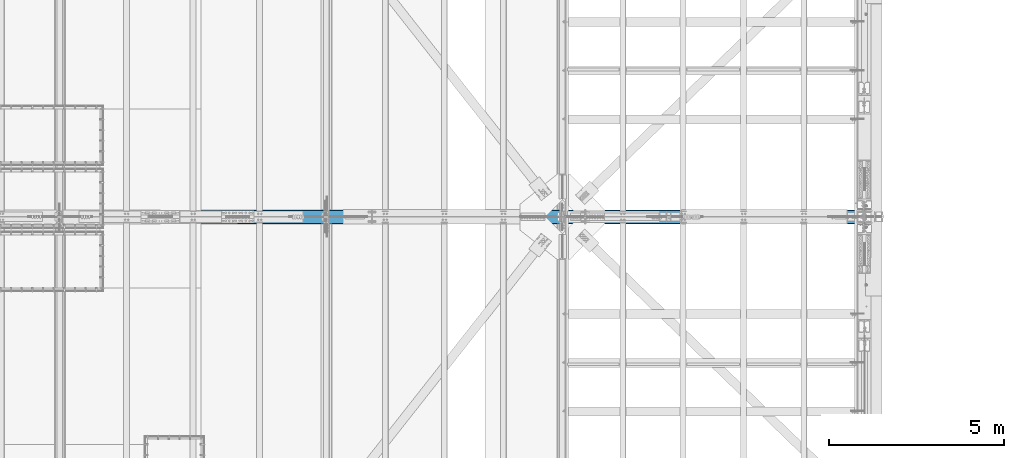
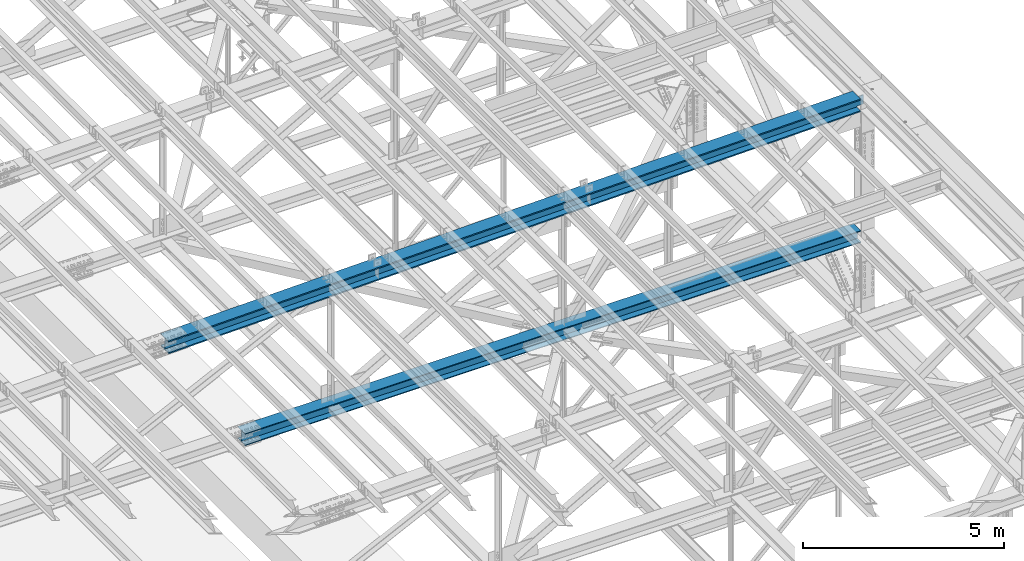
# One storey, part 1861 of 3843: 2 beams, 2 elements without a shape of their own.
"""IFC2X3 building model written with IfcOpenShell, lengths in millimetres."""

from ifc_helpers import new_model, si_unit, frame, origin_with_axes, place, context, subcontext, project, spatial, faceted_brep, material, type_object, element, aggregate, save


model = new_model("IFC2X3")

# Units and contexts
model_context = context("Model", 3, precision=1e-05, world=origin_with_axes())
body_context = subcontext(model_context, "Body", "Model", "MODEL_VIEW")
ifc_project = project(units=[si_unit("LENGTHUNIT", "METRE", prefix="MILLI"), si_unit("AREAUNIT", "SQUARE_METRE"), si_unit("VOLUMEUNIT", "CUBIC_METRE"), si_unit("MASSUNIT", "GRAM", prefix="KILO"), si_unit("TIMEUNIT", "SECOND"), si_unit("PLANEANGLEUNIT", "RADIAN"), si_unit("SOLIDANGLEUNIT", "STERADIAN"), si_unit("THERMODYNAMICTEMPERATUREUNIT", "DEGREE_CELSIUS"), si_unit("LUMINOUSINTENSITYUNIT", "LUMEN")], contexts=[model_context])

# Site, building, storey
site_placement = place(None, origin_with_axes())
site = spatial("IfcSite", under=ifc_project, at=site_placement, CompositionType="ELEMENT")
building_placement = place(site_placement, origin_with_axes())
building = spatial("IfcBuilding", under=site, at=building_placement, Name="Undefined", CompositionType="ELEMENT")
storey_placement = place(building_placement, origin_with_axes())
storey = spatial("IfcBuildingStorey", under=building, at=storey_placement, Name="Undefined", CompositionType="ELEMENT", Elevation=0.0)

# Assembly, beam
assembly_1_placement = place(storey_placement, origin_with_axes())
assembly_1 = element("IfcElementAssembly", 1, at=assembly_1_placement, inside=storey, Name="BEAM", AssemblyPlace="NOTDEFINED", PredefinedType="RIGID_FRAME")
ifc_material = material(Name="STEEL/A992")
beam_type_1 = type_object("IfcBeamType", Name="W14X193", PredefinedType="NOTDEFINED")
beam_1_placement = place(assembly_1_placement, frame((65510.9044385389, 58915.3, 45934.1237435412), z_axis=(-0.0199480780058802, 0.0, 0.999801017294877), x_axis=(0.999801017294877, 0.0, 0.0199480780058834)))
beam_1 = element("IfcBeam", 2, at=beam_1_placement, type_object=beam_type_1, material=ifc_material, Name="BEAM", ObjectType="W14X193", context=body_context, shape_type="Brep", body=[
    faceted_brep([(19920.5114009357, -11.1125000000029, -159.949242872433), (19920.5114009357, -200.025000000001, -159.949242872433), (19920.4414638508, -200.025000000001, -196.461675867919), (19920.4414638508, 200.025000000001, -196.461675867919), (19920.5114009357, 200.025000000001, -159.949242872433), (19920.5114009357, 11.1125000000029, -159.949242872433), (19920.5266857542, 11.1125000000029, -151.969414858671), (19920.5266857542, -11.1125000000029, -151.969414858671), (19921.5027230384, 11.1125000000029, -147.11119595827), (19921.5027230384, -11.1125000000029, -147.11119595827), (19924.2636237923, 11.1125000000029, -142.996300249775), (19924.2636237923, -11.1125000000029, -142.996300249775), (19928.3890659036, 11.1125000000029, -140.25118330316), (19928.3890659036, -11.1125000000029, -140.25118330316), (19933.2509882082, 11.1125000000029, -139.293764288996), (19933.2509882082, -11.1125000000029, -139.293764288996), (20111.3306712136, -11.1125000000029, -139.634863821506), (20111.3306712136, 11.1125000000029, -139.634863821506), (16116.5916279594, 200.025000000001, 203.035264288184), (16116.5916279594, -200.025000000001, 203.035264288184), (18131.211910055, -200.025000000001, 200.329052298759), (18131.211910055, 200.025000000001, 200.329052298759), (14101.9704556068, 200.025000000001, 204.968273136503), (14101.9704556068, -200.025000000001, 204.968273136503), (12087.3486897496, 200.025000000001, 206.128078558737), (12087.3486897496, -200.025000000001, 206.128078558737), (10072.72662714, 200.025000000001, 206.514680384433), (10072.72662714, -200.025000000001, 206.514680384433), (8058.10456453034, 200.025000000001, 206.128078555856), (8058.10456453034, -200.025000000001, 206.128078555856), (6043.48279867311, 200.025000000001, 204.968273130726), (6043.48279867311, -200.025000000001, 204.968273130726), (4028.86162632053, 200.025000000001, 203.035264279511), (4028.86162632053, -200.025000000001, 203.035264279511), (2014.24134422491, 200.025000000001, 200.329052287198), (2014.24134422491, -200.025000000001, 200.329052287198), (5.97224307589931, 200.024999999994, 196.860604494032), (5.97224307589931, -200.024999999994, 196.860604494032), (18131.155856689, 11.1125000000029, 163.816595324934), (18131.155856689, 200.025000000001, 163.816595324934), (19927.4756215503, 200.025000000001, 160.71420169132), (19927.4756215503, 11.1125000000029, 160.71420169132), (16116.5495879277, 11.1125000000029, 166.522788490438), (16116.5495879277, 200.025000000001, 166.522788490438), (14101.9424289156, 11.1125000000029, 168.4557838931), (14101.9424289156, 200.025000000001, 168.4557838931), (12087.3346764029, 11.1125000000029, 169.615581247934), (12087.3346764029, 200.025000000001, 169.615581247934), (10072.72662714, 11.1125000000029, 170.002180384494), (10072.72662714, 200.025000000001, 170.002180384494), (8058.11857787705, 11.1125000000029, 169.615581245045), (8058.11857787705, 200.025000000001, 169.615581245045), (6043.51082536438, 11.1125000000029, 168.45578388733), (6043.51082536438, 200.025000000001, 168.45578388733), (4028.90366635231, 11.1125000000029, 166.522788481765), (4028.90366635231, 200.025000000001, 166.522788481765), (2014.29739759097, 11.1125000000029, 163.816595313379), (2014.29739759097, 200.025000000001, 163.816595313379), (6.04230920456757, 11.1125000000029, 160.348171721198), (6.04230920456757, 200.024999999994, 160.348171721198), (16116.1803667795, 200.025000000001, -154.151998950634), (16116.1803667795, 11.1125000000029, -154.151998950634), (18130.6635619093, 11.1125000000029, -156.858026793001), (18130.6635619093, 200.025000000001, -156.858026793001), (14101.6962814533, 200.025000000001, -152.219121635942), (14101.6962814533, 11.1125000000029, -152.219121635942), (12087.2116026629, 200.025000000001, -151.059395133896), (12087.2116026629, 11.1125000000029, -151.059395133896), (10072.7266271402, 200.025000000001, -150.67281961492), (10072.7266271402, 11.1125000000029, -150.67281961492), (8058.24165161759, 200.025000000001, -151.059395136777), (8058.24165161759, 11.1125000000029, -151.059395136777), (6043.75697282712, 200.025000000001, -152.219121641712), (6043.75697282712, 11.1125000000029, -152.219121641712), (4029.27288750096, 200.025000000001, -154.1519989593), (4029.27288750096, 11.1125000000029, -154.1519989593), (2014.78969237115, 200.025000000001, -156.858026804548), (2014.78969237115, 11.1125000000029, -156.858026804548), (6.657672595451, 200.024999999994, -160.326237848931), (6.657672595451, 11.1125000000029, -160.326237848931), (16116.1383267478, -200.025000000001, -190.664474748381), (16116.1383267478, 200.025000000001, -190.664474748381), (18130.6075085433, 200.025000000001, -193.370483766819), (18130.6075085433, -200.025000000001, -193.370483766819), (14101.6682547621, -200.025000000001, -188.731610879346), (14101.6682547621, 200.025000000001, -188.731610879346), (12087.1975893162, -200.025000000001, -187.571892444692), (12087.1975893162, 200.025000000001, -187.571892444692), (10072.7266271403, -200.025000000001, -187.185319614859), (10072.7266271403, 200.025000000001, -187.185319614859), (8058.25566496428, -200.025000000001, -187.57189244758), (8058.25566496428, 200.025000000001, -187.57189244758), (6043.78499951842, -200.025000000001, -188.731610885123), (6043.78499951842, 200.025000000001, -188.731610885123), (4029.31492753273, -200.025000000001, -190.664474757039), (4029.31492753273, 200.025000000001, -190.664474757039), (2014.84574573721, -200.025000000001, -193.370483778381), (2014.84574573721, 200.025000000001, -193.370483778381), (6.72773872410471, -200.024999999994, -196.838670621779), (6.72773872410471, 200.024999999994, -196.838670621779), (16116.1803667795, -11.1125000000029, -154.151998950634), (16116.1803667795, -200.025000000001, -154.151998950634), (18130.6635619093, -200.025000000001, -156.858026793001), (18130.6635619093, -11.1125000000029, -156.858026793001), (14101.6962814533, -11.1125000000029, -152.219121635942), (14101.6962814533, -200.025000000001, -152.219121635942), (12087.2116026629, -11.1125000000029, -151.059395133896), (12087.2116026629, -200.025000000001, -151.059395133896), (10072.7266271402, -11.1125000000029, -150.67281961492), (10072.7266271402, -200.025000000001, -150.67281961492), (8058.24165161759, -11.1125000000029, -151.059395136777), (8058.24165161759, -200.025000000001, -151.059395136777), (6043.75697282712, -11.1125000000029, -152.219121641712), (6043.75697282712, -200.025000000001, -152.219121641712), (4029.27288750096, -11.1125000000029, -154.1519989593), (4029.27288750096, -200.025000000001, -154.1519989593), (2014.78969237115, -11.1125000000029, -156.858026804548), (2014.78969237115, -200.025000000001, -156.858026804548), (6.657672595451, -11.1125000000029, -160.326237848931), (6.657672595451, -200.024999999994, -160.326237848931), (6.04230920456757, -11.1125000000029, 160.348171721198), (6.04230920456757, -200.024999999994, 160.348171721198), (2014.29739759097, -11.1125000000029, 163.816595313379), (2014.29739759097, -200.025000000001, 163.816595313379), (4028.90366635231, -11.1125000000029, 166.522788481765), (4028.90366635231, -200.025000000001, 166.522788481765), (6043.51082536438, -11.1125000000029, 168.45578388733), (6043.51082536438, -200.025000000001, 168.45578388733), (8058.11857787705, -11.1125000000029, 169.615581245045), (8058.11857787705, -200.025000000001, 169.615581245045), (10072.72662714, -11.1125000000029, 170.002180384494), (10072.72662714, -200.025000000001, 170.002180384494), (12087.3346764029, -11.1125000000029, 169.615581247934), (12087.3346764029, -200.025000000001, 169.615581247934), (14101.9424289156, -11.1125000000029, 168.4557838931), (14101.9424289156, -200.025000000001, 168.4557838931), (16116.5495879277, -11.1125000000029, 166.522788490438), (16116.5495879277, -200.025000000001, 166.522788490438), (18131.155856689, -11.1125000000029, 163.816595324934), (18131.155856689, -200.025000000001, 163.816595324934), (19927.4756215503, -11.1125000000029, 160.71420169132), (19927.4756215503, -200.025000000001, 160.71420169132), (19927.5455586348, -200.025000000001, 197.226634686813), (19927.5455586348, 200.025000000001, 197.226634686813), (19927.4604966495, -11.1125000000029, 152.817862655196), (19927.4604966495, 11.1125000000029, 152.817862655196), (19928.4179156636, -11.1125000000029, 147.955940350577), (19928.4179156636, 11.1125000000029, 147.955940350577), (19931.1630326103, -11.1125000000029, 143.830498239236), (19931.1630326103, 11.1125000000029, 143.830498239236), (19935.2779283188, -11.1125000000029, 141.06959748541), (19935.2779283188, 11.1125000000029, 141.06959748541), (19940.1361472193, -11.1125000000029, 140.093560201218), (19940.1361472193, 11.1125000000029, 140.093560201218), (20116.9050706485, -11.1125000000029, 139.754971339607), (20116.9050706485, 11.1125000000029, 139.754971339607)], [[[0, 1, 2, 3, 4, 5, 6, 7]], [[7, 6, 8, 9]], [[9, 8, 10, 11]], [[11, 10, 12, 13]], [[13, 12, 14, 15]], [[16, 15, 14, 17]], [[18, 19, 20, 21]], [[22, 23, 19, 18]], [[24, 25, 23, 22]], [[26, 27, 25, 24]], [[28, 29, 27, 26]], [[30, 31, 29, 28]], [[32, 33, 31, 30]], [[34, 35, 33, 32]], [[35, 34, 36, 37]], [[38, 39, 40, 41]], [[42, 43, 39, 38]], [[44, 45, 43, 42]], [[46, 47, 45, 44]], [[48, 49, 47, 46]], [[50, 51, 49, 48]], [[52, 53, 51, 50]], [[54, 55, 53, 52]], [[56, 57, 55, 54]], [[57, 56, 58, 59]], [[60, 61, 62, 63]], [[64, 65, 61, 60]], [[66, 67, 65, 64]], [[68, 69, 67, 66]], [[70, 71, 69, 68]], [[72, 73, 71, 70]], [[74, 75, 73, 72]], [[76, 77, 75, 74]], [[77, 76, 78, 79]], [[80, 81, 82, 83]], [[84, 85, 81, 80]], [[86, 87, 85, 84]], [[88, 89, 87, 86]], [[90, 91, 89, 88]], [[92, 93, 91, 90]], [[94, 95, 93, 92]], [[96, 97, 95, 94]], [[97, 96, 98, 99]], [[100, 101, 102, 103]], [[104, 105, 101, 100]], [[106, 107, 105, 104]], [[108, 109, 107, 106]], [[110, 111, 109, 108]], [[112, 113, 111, 110]], [[114, 115, 113, 112]], [[116, 117, 115, 114]], [[117, 116, 118, 119]], [[120, 121, 37, 36, 59, 58, 79, 78, 99, 98, 119, 118]], [[122, 123, 121, 120]], [[123, 122, 124, 125]], [[125, 124, 126, 127]], [[127, 126, 128, 129]], [[129, 128, 130, 131]], [[131, 130, 132, 133]], [[133, 132, 134, 135]], [[135, 134, 136, 137]], [[137, 136, 138, 139]], [[139, 138, 140, 141]], [[20, 19, 23, 25, 27, 29, 31, 33, 35, 37, 121, 123, 125, 127, 129, 131, 133, 135, 137, 139, 141, 142]], [[21, 20, 142, 143]], [[39, 43, 45, 47, 49, 51, 53, 55, 57, 59, 36, 34, 32, 30, 28, 26, 24, 22, 18, 21, 143, 40]], [[142, 141, 140, 144, 145, 41, 40, 143]], [[146, 147, 145, 144]], [[148, 149, 147, 146]], [[150, 151, 149, 148]], [[152, 153, 151, 150]], [[154, 155, 153, 152]], [[155, 154, 16, 17]], [[12, 10, 8, 6, 5, 62, 61, 65, 67, 69, 71, 73, 75, 77, 79, 58, 56, 54, 52, 50, 48, 46, 44, 42, 38, 41, 145, 147, 149, 151, 153, 155, 17, 14]], [[63, 62, 5, 4]], [[82, 81, 85, 87, 89, 91, 93, 95, 97, 99, 78, 76, 74, 72, 70, 68, 66, 64, 60, 63, 4, 3]], [[83, 82, 3, 2]], [[102, 101, 105, 107, 109, 111, 113, 115, 117, 119, 98, 96, 94, 92, 90, 88, 86, 84, 80, 83, 2, 1]], [[103, 102, 1, 0]], [[154, 152, 150, 148, 146, 144, 140, 138, 136, 134, 132, 130, 128, 126, 124, 122, 120, 118, 116, 114, 112, 110, 108, 106, 104, 100, 103, 0, 7, 9, 11, 13, 15, 16]]]),
])
aggregate(assembly_1, [beam_1])

assembly_2_placement = place(storey_placement, origin_with_axes())
assembly_2 = element("IfcElementAssembly", 3, at=assembly_2_placement, inside=storey, Name="BEAM", AssemblyPlace="NOTDEFINED", PredefinedType="RIGID_FRAME")
beam_type_2 = type_object("IfcBeamType", Name="W14X120", PredefinedType="NOTDEFINED")
beam_2_placement = place(assembly_2_placement, frame((67716.4000147658, 58915.3, 42348.1053377418), z_axis=(0.00141386700069416, 0.0, 0.999999000489553), x_axis=(0.999999000489553, 0.0, -0.00141386700069231)))
beam_2 = element("IfcBeam", 4, at=beam_2_placement, type_object=beam_type_2, material=ifc_material, Name="BEAM", ObjectType="W14X120", context=body_context, shape_type="Brep", body=[
    faceted_brep([(3586.3175087303, -185.737500000003, 165.240491250122), (3586.3175087303, -7.14375000000291, 165.240491250122), (5379.61430858172, -7.14375000000291, 166.772749488926), (5379.61430858172, -185.737500000003, 166.772749488926), (1793.02133730304, -185.737500000003, 163.095329965741), (1793.02133730304, -7.14375000000291, 163.095329965741), (6.07599532067252, -185.737500000003, 160.347032091391), (6.07599532067252, -7.14375000000291, 160.347032091391), (14346.1248180988, 185.737500000003, 189.052978727159), (14346.1248180988, -185.737500000003, 189.052978727159), (16139.4291280259, -185.737500000003, 186.9078077054), (16139.4291280259, 185.737500000003, 186.9078077054), (12552.8198797447, 185.737500000003, 190.5852439218), (12552.8198797447, -185.737500000003, 190.5852439218), (10759.5145224392, 185.737500000003, 191.504603110516), (10759.5145224392, -185.737500000003, 191.504603110516), (8966.20895565808, 185.737500000003, 191.811056186198), (8966.20895565808, -185.737500000003, 191.811056186198), (7172.90338887693, 185.737500000003, 191.504603112524), (7172.90338887693, -185.737500000003, 191.504603112524), (5379.59803157147, 185.737500000003, 190.585243925801), (5379.59803157147, -185.737500000003, 190.585243925801), (3586.29309321741, 185.737500000003, 189.052978733162), (3586.29309321741, -185.737500000003, 189.052978733162), (1792.98878329033, 185.737500000003, 186.907807713411), (1792.98878329033, -185.737500000003, 186.907807713411), (6.03530269260227, 185.737500000003, 184.159497322114), (6.03530269260227, -185.737500000003, 184.159497322114), (14346.1004025862, 7.14375000000291, 165.240491244112), (14346.1004025862, 185.737500000003, 165.240491244112), (16139.3965740135, 185.737500000003, 163.09532995773), (16139.3965740135, 7.14375000000291, 163.09532995773), (12552.8036027348, 7.14375000000291, 166.772749484924), (12552.8036027348, 185.737500000003, 166.772749484924), (10759.5063839339, 7.14375000000291, 167.692104501344), (10759.5063839339, 185.737500000003, 167.692104501344), (8966.20895565825, 7.14375000000291, 167.998556186256), (8966.20895565825, 185.737500000003, 167.998556186256), (7172.91152738262, 7.14375000000291, 167.692104503345), (7172.91152738262, 185.737500000003, 167.692104503345), (5379.61430858172, 7.14375000000291, 166.772749488926), (5379.61430858172, 185.737500000003, 166.772749488926), (3586.3175087303, 7.14375000000291, 165.240491250122), (3586.3175087303, 185.737500000003, 165.240491250122), (1793.02133730304, 7.14375000000291, 163.095329965741), (1793.02133730304, 185.737500000003, 163.095329965741), (6.07599532067252, 7.14375000000291, 160.347032091391), (6.07599532067252, 185.737500000003, 160.347032091391), (14345.7716070167, 185.737500000003, -155.434340194181), (14345.7716070167, 7.14375000000291, -155.434340194181), (16138.9581799798, 7.14375000000291, -157.579370377636), (16138.9581799798, 185.737500000003, -157.579370377636), (12552.5844056678, 185.737500000003, -153.902175598327), (12552.5844056678, 7.14375000000291, -153.902175598327), (10759.3967853951, 185.737500000003, -152.982876768889), (10759.3967853951, 7.14375000000291, -152.982876768889), (8966.2089556604, 185.737500000003, -152.676443812969), (8966.2089556604, 7.14375000000291, -152.676443812969), (7173.02112592572, 185.737500000003, -152.982876766888), (7173.02112592572, 7.14375000000291, -152.982876766888), (5379.83350565299, 185.737500000003, -153.902175594325), (5379.83350565299, 7.14375000000291, -153.902175594325), (3586.64630430413, 185.737500000003, -155.434340188171), (3586.64630430413, 7.14375000000291, -155.434340188171), (1793.45973134102, 185.737500000003, -157.579370369625), (1793.45973134102, 7.14375000000291, -157.579370369625), (6.6239893786551, 185.737500000003, -160.327499682498), (6.6239893786551, 7.14375000000291, -160.327499682498), (14345.7471915041, -185.737500000003, -179.24682767722), (14345.7471915041, 185.737500000003, -179.24682767722), (16138.9256259674, 185.737500000003, -181.391848125306), (16138.9256259674, -185.737500000003, -181.391848125306), (12552.5681286579, -185.737500000003, -177.714670035202), (12552.5681286579, 185.737500000003, -177.714670035202), (10759.3886468897, -185.737500000003, -176.795375378075), (10759.3886468897, 185.737500000003, -176.795375378075), (8966.20895566055, -185.737500000003, -176.488943812918), (8966.20895566055, 185.737500000003, -176.488943812918), (7173.0292644314, -185.737500000003, -176.795375376059), (7173.0292644314, 185.737500000003, -176.795375376059), (5379.84978266324, -185.737500000003, -177.714670031201), (5379.84978266324, 185.737500000003, -177.714670031201), (3586.67071981705, -185.737500000003, -179.24682767121), (3586.67071981705, 185.737500000003, -179.24682767121), (1793.49228535374, -185.737500000003, -181.391848117295), (1793.49228535374, 185.737500000003, -181.391848117295), (6.66468200672534, -185.737500000003, -184.139964913236), (6.66468200672534, 185.737500000003, -184.139964913236), (6.6239893786551, -185.737500000003, -160.327499682498), (6.6239893786551, -7.14375000000291, -160.327499682498), (1793.45973134102, -185.737500000003, -157.579370369625), (1793.45973134102, -7.14375000000291, -157.579370369625), (3586.64630430413, -185.737500000003, -155.434340188171), (3586.64630430413, -7.14375000000291, -155.434340188171), (5379.83350565299, -185.737500000003, -153.902175594325), (5379.83350565299, -7.14375000000291, -153.902175594325), (7173.02112592572, -185.737500000003, -152.982876766888), (7173.02112592572, -7.14375000000291, -152.982876766888), (8966.2089556604, -185.737500000003, -152.676443812969), (8966.2089556604, -7.14375000000291, -152.676443812969), (10759.3967853951, -185.737500000003, -152.982876768889), (10759.3967853951, -7.14375000000291, -152.982876768889), (12552.5844056678, -185.737500000003, -153.902175598327), (12552.5844056678, -7.14375000000291, -153.902175598327), (14345.7716070167, -185.737500000003, -155.434340194181), (14345.7716070167, -7.14375000000291, -155.434340194181), (16138.9581799798, -185.737500000003, -157.579370377636), (16138.9581799798, -7.14375000000291, -157.579370377636), (17732.6189726101, -185.737500000003, -160.030399221832), (17732.6189726101, -7.14375000000291, -160.030399221832), (16139.3965740135, -7.14375000000291, 163.09532995773), (14346.1004025862, -7.14375000000291, 165.240491244112), (12552.8036027348, -7.14375000000291, 166.772749484924), (10759.5063839339, -7.14375000000291, 167.692104501344), (8966.20895565825, -7.14375000000291, 167.998556186256), (7172.91152738262, -7.14375000000291, 167.692104503345), (17732.1655788386, -7.14375000000291, 160.645672671169), (7172.91152738262, -185.737500000003, 167.692104503345), (8966.20895565825, -185.737500000003, 167.998556186256), (10759.5063839339, -185.737500000003, 167.692104501344), (12552.8036027348, -185.737500000003, 166.772749484924), (14346.1004025862, -185.737500000003, 165.240491244112), (16139.3965740135, -185.737500000003, 163.09532995773), (17732.1655788386, -185.737500000003, 160.645672671169), (17732.1319109843, -185.737500000003, 184.458252267184), (17732.1319109843, 185.737500000003, 184.458252267184), (17732.1319109843, 147.637589056445, 184.458252267184), (17732.1655788386, 185.737500000003, 160.645672671169), (17732.1655788386, 7.14375000000291, 160.645672671169), (17732.1655788386, 147.637589056445, 160.645672671169), (17732.5637683663, 7.14375000000291, -120.985575159124), (17732.6189726101, 7.14375000000291, -160.030399221832), (17732.2205097341, 7.14375000000291, 121.794182178557), (17732.6189726101, 185.737500000003, -160.030399221832), (17732.6189726101, 147.637589056445, -160.030399221832), (17732.6526404644, 185.737500000003, -183.842978817847), (17732.6526404644, -185.737500000003, -183.842978817847), (17732.6526404644, 147.637589056445, -183.842978817847)], [[[0, 1, 2, 3]], [[4, 5, 1, 0]], [[5, 4, 6, 7]], [[8, 9, 10, 11]], [[12, 13, 9, 8]], [[14, 15, 13, 12]], [[16, 17, 15, 14]], [[18, 19, 17, 16]], [[20, 21, 19, 18]], [[22, 23, 21, 20]], [[24, 25, 23, 22]], [[25, 24, 26, 27]], [[28, 29, 30, 31]], [[32, 33, 29, 28]], [[34, 35, 33, 32]], [[36, 37, 35, 34]], [[38, 39, 37, 36]], [[40, 41, 39, 38]], [[42, 43, 41, 40]], [[44, 45, 43, 42]], [[45, 44, 46, 47]], [[48, 49, 50, 51]], [[52, 53, 49, 48]], [[54, 55, 53, 52]], [[56, 57, 55, 54]], [[58, 59, 57, 56]], [[60, 61, 59, 58]], [[62, 63, 61, 60]], [[64, 65, 63, 62]], [[65, 64, 66, 67]], [[68, 69, 70, 71]], [[72, 73, 69, 68]], [[74, 75, 73, 72]], [[76, 77, 75, 74]], [[78, 79, 77, 76]], [[80, 81, 79, 78]], [[82, 83, 81, 80]], [[84, 85, 83, 82]], [[85, 84, 86, 87]], [[7, 6, 27, 26, 47, 46, 67, 66, 87, 86, 88, 89]], [[90, 91, 89, 88]], [[91, 90, 92, 93]], [[93, 92, 94, 95]], [[95, 94, 96, 97]], [[97, 96, 98, 99]], [[99, 98, 100, 101]], [[101, 100, 102, 103]], [[103, 102, 104, 105]], [[105, 104, 106, 107]], [[107, 106, 108, 109]], [[110, 111, 112, 113, 114, 115, 2, 1, 5, 7, 89, 91, 93, 95, 97, 99, 101, 103, 105, 107, 109, 116]], [[3, 2, 115, 117]], [[10, 9, 13, 15, 17, 19, 21, 23, 25, 27, 6, 4, 0, 3, 117, 118, 119, 120, 121, 122, 123, 124]], [[125, 11, 10, 124, 126]], [[30, 29, 33, 35, 37, 39, 41, 43, 45, 47, 26, 24, 22, 20, 18, 16, 14, 12, 8, 11, 125, 127]], [[128, 31, 30, 127, 129]], [[130, 131, 50, 49, 53, 55, 57, 59, 61, 63, 65, 67, 46, 44, 42, 40, 38, 36, 34, 32, 28, 31, 128, 132]], [[133, 51, 50, 131, 134]], [[70, 69, 73, 75, 77, 79, 81, 83, 85, 87, 66, 64, 62, 60, 58, 56, 54, 52, 48, 51, 133, 135]], [[136, 71, 70, 135, 137]], [[106, 104, 102, 100, 98, 96, 94, 92, 90, 88, 86, 84, 82, 80, 78, 76, 74, 72, 68, 71, 136, 108]], [[137, 135, 133, 134, 131, 130, 132, 128, 129, 127, 125, 126, 124, 123, 116, 109, 108, 136]], [[122, 110, 116, 123]], [[121, 111, 110, 122]], [[120, 112, 111, 121]], [[119, 113, 112, 120]], [[118, 114, 113, 119]], [[117, 115, 114, 118]]]),
])
aggregate(assembly_2, [beam_2])

save(model, "model.ifc")
